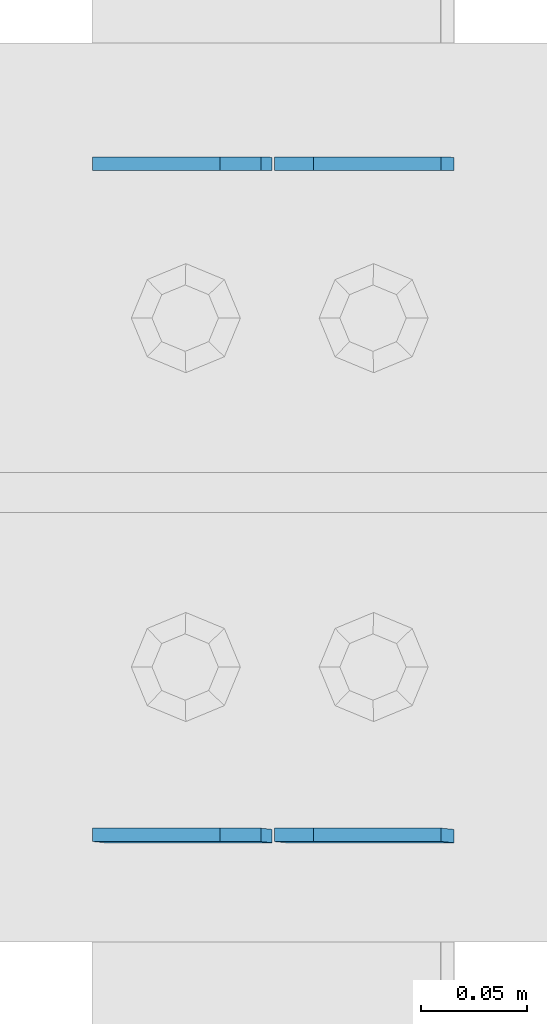
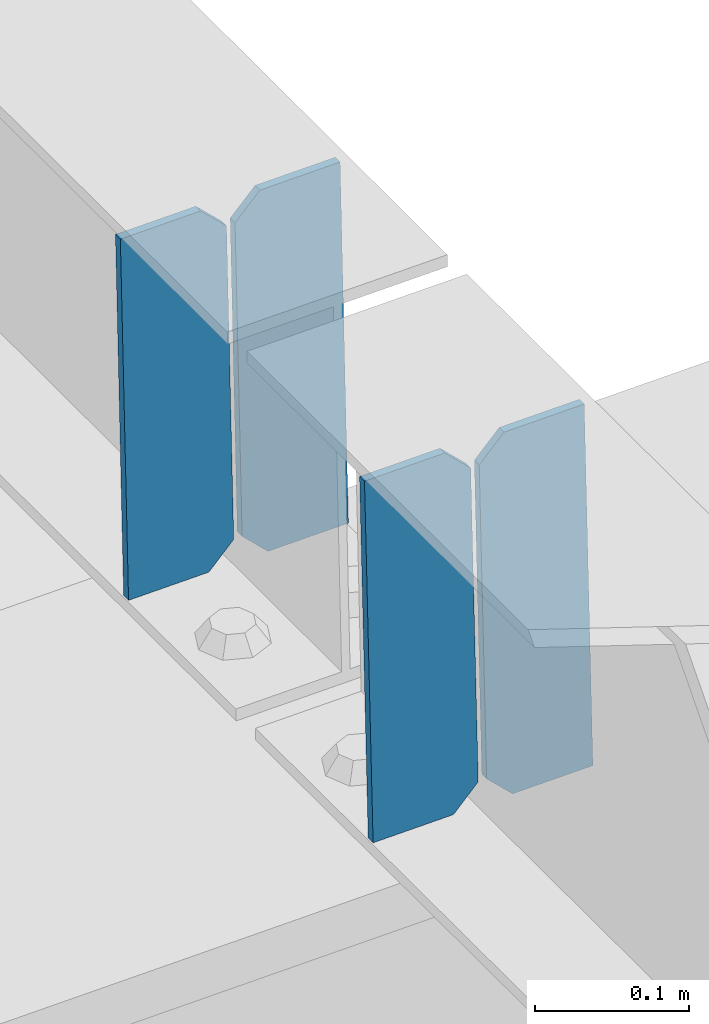
# One storey, part 3399 of 3843: 4 plates, 2 elements without a shape of their own.
"""IFC2X3 building model written with IfcOpenShell, lengths in millimetres."""

from ifc_helpers import new_model, si_unit, frame, origin_with_axes, place, context, subcontext, project, spatial, faceted_brep, material, type_object, element, aggregate, save


model = new_model("IFC2X3")

# Units and contexts
model_context = context("Model", 3, precision=1e-05, world=origin_with_axes())
body_context = subcontext(model_context, "Body", "Model", "MODEL_VIEW")
ifc_project = project(units=[si_unit("LENGTHUNIT", "METRE", prefix="MILLI"), si_unit("AREAUNIT", "SQUARE_METRE"), si_unit("VOLUMEUNIT", "CUBIC_METRE"), si_unit("MASSUNIT", "GRAM", prefix="KILO"), si_unit("TIMEUNIT", "SECOND"), si_unit("PLANEANGLEUNIT", "RADIAN"), si_unit("SOLIDANGLEUNIT", "STERADIAN"), si_unit("THERMODYNAMICTEMPERATUREUNIT", "DEGREE_CELSIUS"), si_unit("LUMINOUSINTENSITYUNIT", "LUMEN")], contexts=[model_context])

# Site, building, storey
site_placement = place(None, origin_with_axes())
site = spatial("IfcSite", under=ifc_project, at=site_placement, CompositionType="ELEMENT")
building_placement = place(site_placement, origin_with_axes())
building = spatial("IfcBuilding", under=site, at=building_placement, Name="Undefined", CompositionType="ELEMENT")
storey_placement = place(building_placement, origin_with_axes())
storey = spatial("IfcBuildingStorey", under=building, at=storey_placement, Name="Undefined", CompositionType="ELEMENT", Elevation=0.0)

# Assembly, plates
assembly_1_placement = place(storey_placement, origin_with_axes())
assembly_1 = element("IfcElementAssembly", 1, at=assembly_1_placement, inside=storey, Name="BEAM", AssemblyPlace="NOTDEFINED", PredefinedType="RIGID_FRAME")
ifc_material = material(Name="STEEL/A572-50")
plate_type = type_object("IfcPlateType", PredefinedType="NOTDEFINED")
plate_1_placement = place(assembly_1_placement, frame((40773.0964783431, 84140.608009931, 45520.237632514), z_axis=(-0.0211520975410895, 0.000224553000021843, 0.999776244139439), x_axis=(-0.999776269357106, -4.75100003261494e-06, -0.0211520970075272)))
plate_1 = element("IfcPlate", 2, at=plate_1_placement, type_object=plate_type, material=ifc_material, Name="PLATE", context=body_context, shape_type="Brep", body=[
    faceted_brep([(0.0, -3.17499999999927, 0.0), (6.83940015733242e-10, -3.17499999996653, 288.924999998613), (6.54836185276508e-10, 3.17500000001746, 288.924999998591), (0.0, 3.17499999999927, 0.0), (60.3250007643655, -3.17500000017753, 288.924999998606), (60.3250007643219, 3.17499999979918, 288.924999998584), (79.3750000013097, -3.17500000025029, 269.875000761494), (79.375000001266, 3.17499999972642, 269.875000761487), (79.375000000713, -3.17500000026484, 19.0499992370605), (79.3750000006985, 3.17499999971187, 19.0499992370533), (60.325000763667, -3.17500000020664, -1.45519152283669e-11), (60.3250007636234, 3.17499999977736, -3.63797880709171e-11)], [[[0, 1, 2, 3]], [[1, 4, 5, 2]], [[4, 6, 7, 5]], [[6, 8, 9, 7]], [[8, 10, 11, 9]], [[10, 0, 3, 11]], [[5, 7, 9, 11, 3, 2]], [[10, 8, 6, 4, 1, 0]]]),
])
plate_2_placement = place(assembly_1_placement, frame((40687.3906576538, 84140.6076026668, 45518.424368958), z_axis=(-0.0211520975410895, 0.000224553000021843, 0.999776244139439), x_axis=(-0.999776269357106, -4.75100003261494e-06, -0.0211520970075272)))
plate_2 = element("IfcPlate", 3, at=plate_2_placement, type_object=plate_type, material=ifc_material, Name="PLATE", context=body_context, shape_type="Brep", body=[
    faceted_brep([(4.36557456851006e-11, -3.17499999998836, 19.0499992370969), (6.11180439591408e-10, -3.17499999996653, 269.875000761516), (5.96628524363041e-10, 3.17500000001746, 269.875000761502), (1.45519152283669e-11, 3.17499999998836, 19.0499992370824), (19.0499992376572, -3.17500000003201, 288.924999998606), (19.0499992376281, 3.1749999999447, 288.924999998584), (79.3750000013242, -3.17500000025029, 288.924999998591), (79.3750000013097, 3.1749999997337, 288.92499999857), (79.3750000006548, -3.17500000026484, -2.18278728425503e-11), (79.3750000006403, 3.17499999969732, -2.91038304567337e-11), (19.0499992370023, -3.17500000005384, 0.0), (19.0499992369587, 3.17499999992287, -1.45519152283669e-11)], [[[0, 1, 2, 3]], [[1, 4, 5, 2]], [[4, 6, 7, 5]], [[6, 8, 9, 7]], [[8, 10, 11, 9]], [[10, 0, 3, 11]], [[5, 7, 9, 11, 3, 2]], [[10, 8, 6, 4, 1, 0]]]),
])
aggregate(assembly_1, [plate_1, plate_2])

assembly_2_placement = place(storey_placement, origin_with_axes())
assembly_2 = element("IfcElementAssembly", 4, at=assembly_2_placement, inside=storey, Name="BEAM", AssemblyPlace="NOTDEFINED", PredefinedType="RIGID_FRAME")
plate_3_placement = place(assembly_2_placement, frame((40773.0964783089, 83822.5304468278, 45520.6243589569), z_axis=(-0.0211520975252424, 0.00216334199957782, 0.999773928806746), x_axis=(-0.999776269356297, -4.57939999836346e-05, -0.021152048007558)))
plate_3 = element("IfcPlate", 5, at=plate_3_placement, type_object=plate_type, material=ifc_material, Name="PLATE", context=body_context, shape_type="Brep", body=[
    faceted_brep([(0.0, -3.17499999999927, 0.0), (6.83940015733242e-10, -3.17499999996653, 288.924999998613), (6.54836185276508e-10, 3.17500000001746, 288.924999998591), (0.0, 3.17499999999927, 0.0), (60.3250007643655, -3.17500000017753, 288.924999998606), (60.3250007643219, 3.17499999979918, 288.924999998584), (79.3750000013097, -3.17500000025029, 269.875000761494), (79.375000001266, 3.17499999972642, 269.875000761487), (79.375000000713, -3.17500000026484, 19.0499992370605), (79.3750000006985, 3.17499999971187, 19.0499992370533), (60.325000763667, -3.17500000020664, -1.45519152283669e-11), (60.3250007636234, 3.17499999977736, -3.63797880709171e-11)], [[[0, 1, 2, 3]], [[1, 4, 5, 2]], [[4, 6, 7, 5]], [[6, 8, 9, 7]], [[8, 10, 11, 9]], [[10, 0, 3, 11]], [[5, 7, 9, 11, 3, 2]], [[10, 8, 6, 4, 1, 0]]]),
])
plate_4_placement = place(assembly_2_placement, frame((40687.3906576196, 83822.5265232388, 45518.8110996018), z_axis=(-0.0211520975252424, 0.00216334199957782, 0.999773928806746), x_axis=(-0.999776269356297, -4.57939999836346e-05, -0.021152048007558)))
plate_4 = element("IfcPlate", 6, at=plate_4_placement, type_object=plate_type, material=ifc_material, Name="PLATE", context=body_context, shape_type="Brep", body=[
    faceted_brep([(4.36557456851006e-11, -3.17499999998836, 19.0499992370969), (6.11180439591408e-10, -3.17499999996653, 269.875000761516), (5.96628524363041e-10, 3.17500000001746, 269.875000761502), (1.45519152283669e-11, 3.17499999998836, 19.0499992370824), (19.0499992376572, -3.17500000003201, 288.924999998606), (19.0499992376281, 3.1749999999447, 288.924999998584), (79.3750000013242, -3.17500000025029, 288.924999998591), (79.3750000013097, 3.1749999997337, 288.92499999857), (79.3750000006548, -3.17500000026484, -2.18278728425503e-11), (79.3750000006403, 3.17499999969732, -2.91038304567337e-11), (19.0499992370023, -3.17500000005384, 0.0), (19.0499992369587, 3.17499999992287, -1.45519152283669e-11)], [[[0, 1, 2, 3]], [[1, 4, 5, 2]], [[4, 6, 7, 5]], [[6, 8, 9, 7]], [[8, 10, 11, 9]], [[10, 0, 3, 11]], [[5, 7, 9, 11, 3, 2]], [[10, 8, 6, 4, 1, 0]]]),
])
aggregate(assembly_2, [plate_3, plate_4])

save(model, "model.ifc")
